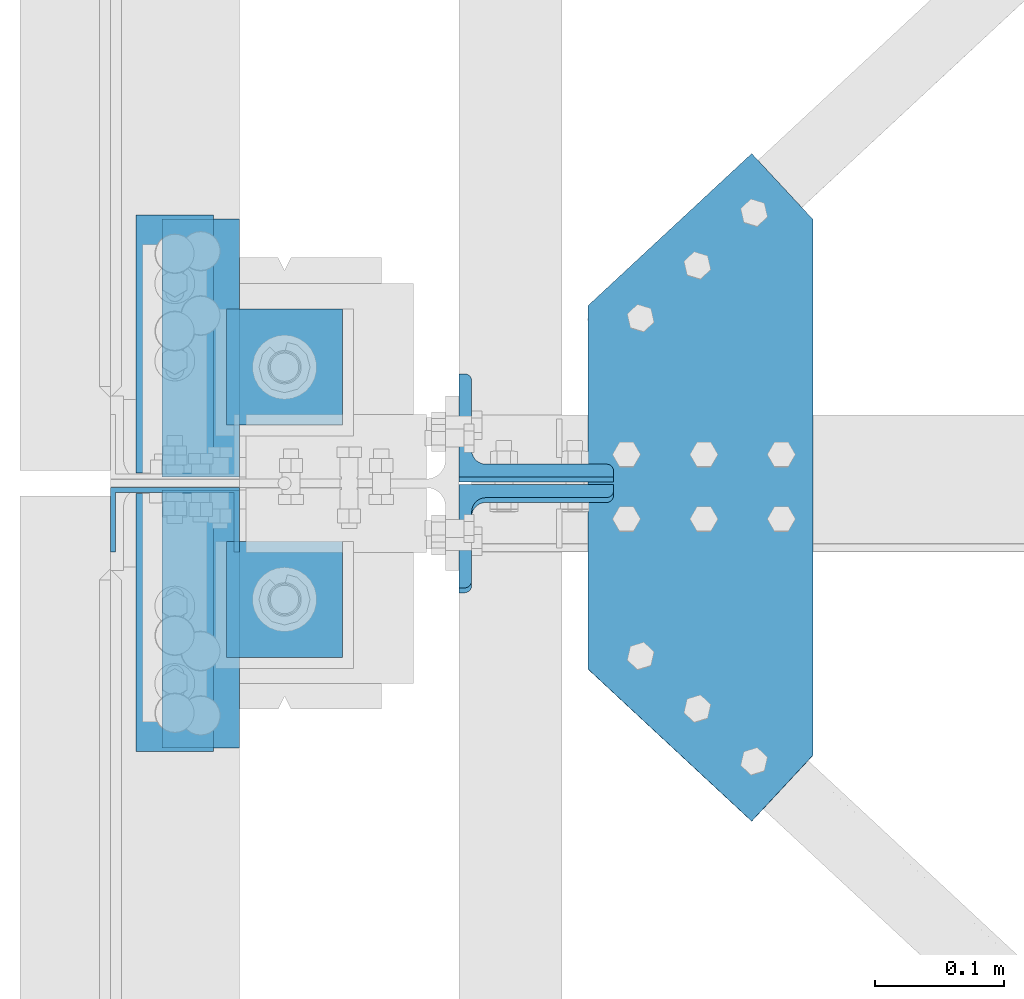
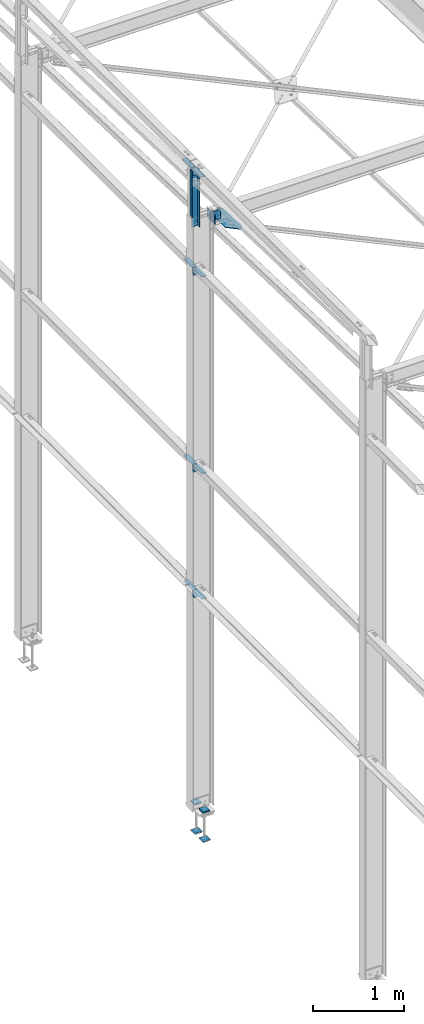
# One storey, part 72 of 496: 14 beams, 2 members, 13 elements without a shape of their own.
"""IFC2X3 building model written with IfcOpenShell, lengths in millimetres."""

from ifc_helpers import new_model, si_unit, frame, origin_with_axes, origin_2d_with_axis, place, context, subcontext, project, spatial, polyline, l_section, u_section, outline, extrude, boolean, material, type_object, element, aggregate, save


model = new_model("IFC2X3")

# Units and contexts
model_context = context("Model", 3, precision=1e-05, world=origin_with_axes())
body_context = subcontext(model_context, "Body", "Model", "MODEL_VIEW")
ifc_project = project(units=[si_unit("LENGTHUNIT", "METRE", prefix="MILLI"), si_unit("AREAUNIT", "SQUARE_METRE"), si_unit("VOLUMEUNIT", "CUBIC_METRE"), si_unit("MASSUNIT", "GRAM", prefix="KILO"), si_unit("TIMEUNIT", "SECOND"), si_unit("PLANEANGLEUNIT", "RADIAN"), si_unit("SOLIDANGLEUNIT", "STERADIAN"), si_unit("THERMODYNAMICTEMPERATUREUNIT", "DEGREE_CELSIUS"), si_unit("LUMINOUSINTENSITYUNIT", "LUMEN")], contexts=[model_context])

# Site, building, storey
site_placement = place(None, origin_with_axes())
site = spatial("IfcSite", under=ifc_project, at=site_placement, CompositionType="ELEMENT")
building_placement = place(site_placement, origin_with_axes())
building = spatial("IfcBuilding", under=site, at=building_placement, Name="Undefined", CompositionType="ELEMENT")
storey_placement = place(building_placement, origin_with_axes())
storey = spatial("IfcBuildingStorey", under=building, at=storey_placement, Name="Undefined", CompositionType="ELEMENT", Elevation=0.0)

# Assembly, beam
assembly_1_placement = place(storey_placement, origin_with_axes())
assembly_1 = element("IfcElementAssembly", 1, at=assembly_1_placement, inside=storey, AssemblyPlace="NOTDEFINED", PredefinedType="NOTDEFINED")
ifc_material = material(Name="Undefined/S235-E24")
beam_type_1 = type_object("IfcBeamType", PredefinedType="NOTDEFINED")
beam_1_placement = place(assembly_1_placement, frame((-130.000001390421, 7571.70000007728, 8444.9989692274), z_axis=(1.0, 0.0, 0.0), x_axis=(0.0, 0.0, -1.0)))
beam_1 = element("IfcBeam", 2, at=beam_1_placement, type_object=beam_type_1, material=ifc_material, context=body_context, shape_type="CSG", body=[
    boolean("DIFFERENCE", extrude(u_section(Depth=100.0, FlangeWidth=50.0, WebThickness=4.0, FlangeThickness=4.0, at=origin_2d_with_axis()), frame((789.998684463202, 0.0, 0.0), z_axis=(-1.0, 0.0, 0.0), x_axis=(0.0, -1.0, 0.0)), (0.0, 0.0, 1.0), 790.0), extrude(outline(polyline([(0.0, 0.0), (20.0, 0.0), (19.9999939326024, 170.0), (-6.06739681074941e-06, 170.0), (0.0, 0.0)])), frame((619.998558986588, -27.5000000297823, -50.0000000000008), z_axis=(0.0, 1.0, 0.0), x_axis=(0.0, 0.0, 1.0)), (0.0, 0.0, 1.0), 55.0)),
])
aggregate(assembly_1, [beam_1])

assembly_2_placement = place(storey_placement, origin_with_axes())
assembly_2 = element("IfcElementAssembly", 3, at=assembly_2_placement, inside=storey, AssemblyPlace="NOTDEFINED", PredefinedType="NOTDEFINED")
beam_type_2 = type_object("IfcBeamType", PredefinedType="NOTDEFINED")
beam_2_placement = place(assembly_2_placement, frame((190.000000810861, 7737.43555853868, 7603.74442003857), z_axis=(0.0, -0.031410887010906, -0.999506556345274), x_axis=(0.732434511694635, 0.680501526716288, -0.0213859349910859)))
beam_2 = element("IfcBeam", 4, at=beam_2_placement, type_object=beam_type_2, material=ifc_material, context=body_context, shape_type="SweptSolid", body=[
    extrude(outline(polyline([(0.0, 0.0), (173.397750853316, 2.20097717829049e-10), (173.397735594586, 70.0000000001428), (-109.18592071591, 373.992950438941), (-178.999572754413, 379.097320556037), (-191.641067505524, 206.164520263229), (0.0, 0.0)])), frame((0.0, 0.0, -3.0), z_axis=(0.0, 0.0, 1.0), x_axis=(1.0, 0.0, 0.0)), (0.0, 0.0, 1.0), 6.0),
])
aggregate(assembly_2, [beam_2])

assembly_3_placement = place(storey_placement, origin_with_axes())
assembly_3 = element("IfcElementAssembly", 5, at=assembly_3_placement, inside=storey, AssemblyPlace="NOTDEFINED", PredefinedType="NOTDEFINED")
beam_type_3 = type_object("IfcBeamType", PredefinedType="NOTDEFINED")
beam_3_placement = place(assembly_3_placement, frame((-99.9999997873019, 7708.0, 8400.0), z_axis=(0.0, 1.0, 0.0), x_axis=(-1.0, 0.0, 0.0)))
beam_3 = element("IfcBeam", 6, at=beam_3_placement, type_object=beam_type_3, material=ifc_material, context=body_context, shape_type="SweptSolid", body=[
    extrude(l_section(Depth=200.0, Width=100.0, Thickness=10.0, FilletRadius=15.0, EdgeRadius=7.5, at=origin_2d_with_axis()), frame((60.0, 0.0, 0.0), z_axis=(-1.0, 0.0, 0.0), x_axis=(0.0, -1.0, 0.0)), (0.0, 0.0, 1.0), 60.0),
])
aggregate(assembly_3, [beam_3])

assembly_4_placement = place(storey_placement, origin_with_axes())
assembly_4 = element("IfcElementAssembly", 7, at=assembly_4_placement, inside=storey, AssemblyPlace="NOTDEFINED", PredefinedType="NOTDEFINED")
beam_4_placement = place(assembly_4_placement, frame((-159.999999787302, 7492.0, 8400.0), z_axis=(0.0, -1.0, 0.0), x_axis=(1.0, 0.0, 0.0)))
beam_4 = element("IfcBeam", 8, at=beam_4_placement, type_object=beam_type_3, material=ifc_material, context=body_context, shape_type="SweptSolid", body=[
    extrude(l_section(Depth=200.0, Width=100.0, Thickness=10.0, FilletRadius=15.0, EdgeRadius=7.5, at=origin_2d_with_axis()), frame((60.0, 0.0, 0.0), z_axis=(-1.0, 0.0, 0.0), x_axis=(0.0, -1.0, 0.0)), (0.0, 0.0, 1.0), 60.0),
])
aggregate(assembly_4, [beam_4])

assembly_5_placement = place(storey_placement, origin_with_axes())
assembly_5 = element("IfcElementAssembly", 9, at=assembly_5_placement, inside=storey, AssemblyPlace="NOTDEFINED", PredefinedType="NOTDEFINED")
beam_5_placement = place(assembly_5_placement, frame((-80.000006857158, 7705.00000064863, 2709.9999839346), z_axis=(0.0, 1.0, 0.0), x_axis=(-1.0, 0.0, 0.0)))
beam_5 = element("IfcBeam", 10, at=beam_5_placement, type_object=beam_type_3, material=ifc_material, context=body_context, shape_type="SweptSolid", body=[
    extrude(l_section(Depth=200.0, Width=100.0, Thickness=10.0, FilletRadius=15.0, EdgeRadius=7.5, at=origin_2d_with_axis()), frame((60.0, 0.0, 0.0), z_axis=(-1.0, 0.0, 0.0), x_axis=(0.0, -1.0, 0.0)), (0.0, 0.0, 1.0), 60.0),
])
aggregate(assembly_5, [beam_5])

assembly_6_placement = place(storey_placement, origin_with_axes())
assembly_6 = element("IfcElementAssembly", 11, at=assembly_6_placement, inside=storey, AssemblyPlace="NOTDEFINED", PredefinedType="NOTDEFINED")
beam_6_placement = place(assembly_6_placement, frame((-140.000006178405, 7495.00000045483, 2709.9999839346), z_axis=(0.0, -1.0, 0.0), x_axis=(1.0, 0.0, 0.0)))
beam_6 = element("IfcBeam", 12, at=beam_6_placement, type_object=beam_type_3, material=ifc_material, context=body_context, shape_type="SweptSolid", body=[
    extrude(l_section(Depth=200.0, Width=100.0, Thickness=10.0, FilletRadius=15.0, EdgeRadius=7.5, at=origin_2d_with_axis()), frame((60.0, 0.0, 0.0), z_axis=(-1.0, 0.0, 0.0), x_axis=(0.0, -1.0, 0.0)), (0.0, 0.0, 1.0), 60.0),
])
aggregate(assembly_6, [beam_6])

assembly_7_placement = place(storey_placement, origin_with_axes())
assembly_7 = element("IfcElementAssembly", 13, at=assembly_7_placement, inside=storey, AssemblyPlace="NOTDEFINED", PredefinedType="NOTDEFINED")
beam_7_placement = place(assembly_7_placement, frame((-80.000006857158, 7705.00000064863, 4399.99998404937), z_axis=(0.0, 1.0, 0.0), x_axis=(-1.0, 0.0, 0.0)))
beam_7 = element("IfcBeam", 14, at=beam_7_placement, type_object=beam_type_3, material=ifc_material, context=body_context, shape_type="SweptSolid", body=[
    extrude(l_section(Depth=200.0, Width=100.0, Thickness=10.0, FilletRadius=15.0, EdgeRadius=7.5, at=origin_2d_with_axis()), frame((60.0, 0.0, 0.0), z_axis=(-1.0, 0.0, 0.0), x_axis=(0.0, -1.0, 0.0)), (0.0, 0.0, 1.0), 60.0),
])
aggregate(assembly_7, [beam_7])

assembly_8_placement = place(storey_placement, origin_with_axes())
assembly_8 = element("IfcElementAssembly", 15, at=assembly_8_placement, inside=storey, AssemblyPlace="NOTDEFINED", PredefinedType="NOTDEFINED")
beam_8_placement = place(assembly_8_placement, frame((-140.000006178405, 7495.00000045483, 4399.99998404937), z_axis=(0.0, -1.0, 0.0), x_axis=(1.0, 0.0, 0.0)))
beam_8 = element("IfcBeam", 16, at=beam_8_placement, type_object=beam_type_3, material=ifc_material, context=body_context, shape_type="SweptSolid", body=[
    extrude(l_section(Depth=200.0, Width=100.0, Thickness=10.0, FilletRadius=15.0, EdgeRadius=7.5, at=origin_2d_with_axis()), frame((60.0, 0.0, 0.0), z_axis=(-1.0, 0.0, 0.0), x_axis=(0.0, -1.0, 0.0)), (0.0, 0.0, 1.0), 60.0),
])
aggregate(assembly_8, [beam_8])

assembly_9_placement = place(storey_placement, origin_with_axes())
assembly_9 = element("IfcElementAssembly", 17, at=assembly_9_placement, inside=storey, AssemblyPlace="NOTDEFINED", PredefinedType="NOTDEFINED")
beam_9_placement = place(assembly_9_placement, frame((-80.000006857158, 7705.00000064863, 7050.0), z_axis=(0.0, 1.0, 0.0), x_axis=(-1.0, 0.0, 0.0)))
beam_9 = element("IfcBeam", 18, at=beam_9_placement, type_object=beam_type_3, material=ifc_material, context=body_context, shape_type="SweptSolid", body=[
    extrude(l_section(Depth=200.0, Width=100.0, Thickness=10.0, FilletRadius=15.0, EdgeRadius=7.5, at=origin_2d_with_axis()), frame((60.0, 0.0, 0.0), z_axis=(-1.0, 0.0, 0.0), x_axis=(0.0, -1.0, 0.0)), (0.0, 0.0, 1.0), 60.0),
])
aggregate(assembly_9, [beam_9])

assembly_10_placement = place(storey_placement, origin_with_axes())
assembly_10 = element("IfcElementAssembly", 19, at=assembly_10_placement, inside=storey, AssemblyPlace="NOTDEFINED", PredefinedType="NOTDEFINED")
beam_10_placement = place(assembly_10_placement, frame((-140.000006178405, 7495.00000045483, 7050.0), z_axis=(0.0, -1.0, 0.0), x_axis=(1.0, 0.0, 0.0)))
beam_10 = element("IfcBeam", 20, at=beam_10_placement, type_object=beam_type_3, material=ifc_material, context=body_context, shape_type="SweptSolid", body=[
    extrude(l_section(Depth=200.0, Width=100.0, Thickness=10.0, FilletRadius=15.0, EdgeRadius=7.5, at=origin_2d_with_axis()), frame((60.0, 0.0, 0.0), z_axis=(-1.0, 0.0, 0.0), x_axis=(0.0, -1.0, 0.0)), (0.0, 0.0, 1.0), 60.0),
])
aggregate(assembly_10, [beam_10])

# Assembly, member
assembly_11_placement = place(storey_placement, origin_with_axes())
assembly_11 = element("IfcElementAssembly", 21, at=assembly_11_placement, inside=storey, AssemblyPlace="NOTDEFINED", PredefinedType="NOTDEFINED")
member_type = type_object("IfcMemberType", PredefinedType="NOTDEFINED")
member_1_placement = place(assembly_11_placement, frame((149.999999999401, 7641.09495636474, 7649.78811301444), z_axis=(1.0, 0.0, 0.0), x_axis=(0.0, 0.031410887010906, 0.999506556345274)))
member_1 = element("IfcMember", 22, at=member_1_placement, type_object=member_type, material=ifc_material, context=body_context, shape_type="SweptSolid", body=[
    extrude(l_section(Depth=120.0, Width=80.0, Thickness=10.0, FilletRadius=11.0, EdgeRadius=5.5, at=origin_2d_with_axis()), frame((120.0, 0.0, 0.0), z_axis=(-1.0, 0.0, 0.0), x_axis=(0.0, -1.0, 0.0)), (0.0, 0.0, 1.0), 120.0),
])
aggregate(assembly_11, [member_1])

assembly_12_placement = place(storey_placement, origin_with_axes())
assembly_12 = element("IfcElementAssembly", 23, at=assembly_12_placement, inside=storey, AssemblyPlace="NOTDEFINED", PredefinedType="NOTDEFINED")
member_2_placement = place(assembly_12_placement, frame((149.999999999459, 7558.9058777135, 7772.43029036204), z_axis=(1.0, 0.0, 0.0), x_axis=(0.0, -0.031410887010906, -0.999506556345274)))
member_2 = element("IfcMember", 24, at=member_2_placement, type_object=member_type, material=ifc_material, context=body_context, shape_type="SweptSolid", body=[
    extrude(l_section(Depth=120.0, Width=80.0, Thickness=10.0, FilletRadius=11.0, EdgeRadius=5.5, at=origin_2d_with_axis()), frame((120.0, 0.0, 0.0), z_axis=(-1.0, 0.0, 0.0), x_axis=(0.0, -1.0, 0.0)), (0.0, 0.0, 1.0), 120.0),
])
aggregate(assembly_12, [member_2])

# Assembly, beams
assembly_13_placement = place(storey_placement, origin_with_axes())
assembly_13 = element("IfcElementAssembly", 25, at=assembly_13_placement, inside=storey, Name="PS24", AssemblyPlace="NOTDEFINED", PredefinedType="NOTDEFINED")
beam_type_4 = type_object("IfcBeamType", PredefinedType="NOTDEFINED")
beam_11_placement = place(assembly_13_placement, frame((0.0, 7554.99715044471, -177.5), z_axis=(0.0, 0.0, 1.0), x_axis=(-1.0, 0.0, 0.0)))
beam_11 = element("IfcBeam", 26, at=beam_11_placement, type_object=beam_type_4, material=ifc_material, context=body_context, shape_type="SweptSolid", body=[
    extrude(outline(polyline([(0.0, 0.0), (90.0, 0.0), (90.0, 90.0), (0.0, 90.0), (0.0, 0.0)])), frame((0.0, 0.0, -7.5), z_axis=(0.0, 0.0, 1.0), x_axis=(1.0, 0.0, 0.0)), (0.0, 0.0, 1.0), 15.0),
])
beam_12_placement = place(assembly_13_placement, frame((0.0, 7734.99715044471, -177.5), z_axis=(0.0, 0.0, 1.0), x_axis=(-1.0, 0.0, 0.0)))
beam_12 = element("IfcBeam", 27, at=beam_12_placement, type_object=beam_type_4, material=ifc_material, context=body_context, shape_type="SweptSolid", body=[
    extrude(outline(polyline([(0.0, 0.0), (90.0, 0.0), (90.0, 90.0), (0.0, 90.0), (0.0, 0.0)])), frame((0.0, 0.0, -7.5), z_axis=(0.0, 0.0, 1.0), x_axis=(1.0, 0.0, 0.0)), (0.0, 0.0, 1.0), 15.0),
])
beam_13_placement = place(assembly_13_placement, frame((0.0, 7554.99715044471, -572.5), z_axis=(0.0, 0.0, 1.0), x_axis=(-1.0, 0.0, 0.0)))
beam_13 = element("IfcBeam", 28, at=beam_13_placement, type_object=beam_type_4, material=ifc_material, context=body_context, shape_type="SweptSolid", body=[
    extrude(outline(polyline([(0.0, 0.0), (90.0, 0.0), (90.0, 90.0), (0.0, 90.0), (0.0, 0.0)])), frame((0.0, 0.0, -7.5), z_axis=(0.0, 0.0, 1.0), x_axis=(1.0, 0.0, 0.0)), (0.0, 0.0, 1.0), 15.0),
])
beam_14_placement = place(assembly_13_placement, frame((0.0, 7734.99715044471, -572.5), z_axis=(0.0, 0.0, 1.0), x_axis=(-1.0, 0.0, 0.0)))
beam_14 = element("IfcBeam", 29, at=beam_14_placement, type_object=beam_type_4, material=ifc_material, context=body_context, shape_type="SweptSolid", body=[
    extrude(outline(polyline([(0.0, 0.0), (90.0, 0.0), (90.0, 90.0), (0.0, 90.0), (0.0, 0.0)])), frame((0.0, 0.0, -7.5), z_axis=(0.0, 0.0, 1.0), x_axis=(1.0, 0.0, 0.0)), (0.0, 0.0, 1.0), 15.0),
])
aggregate(assembly_13, [beam_11, beam_12, beam_13, beam_14])

save(model, "model.ifc")
